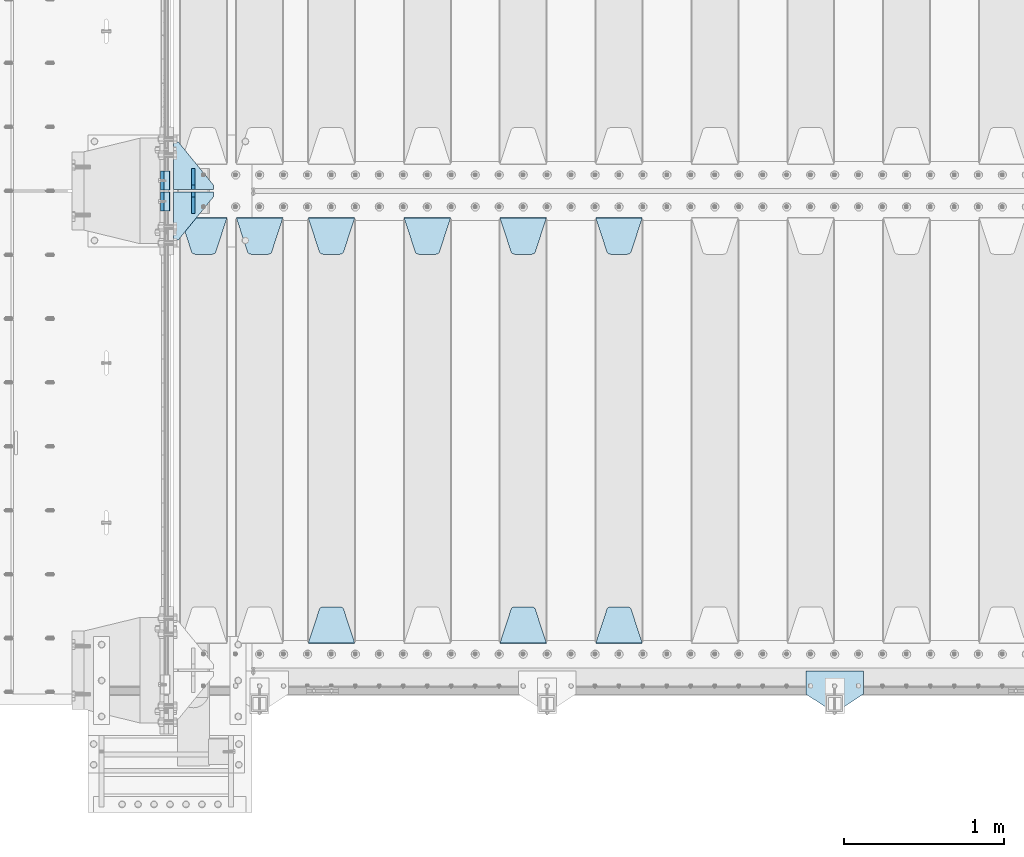
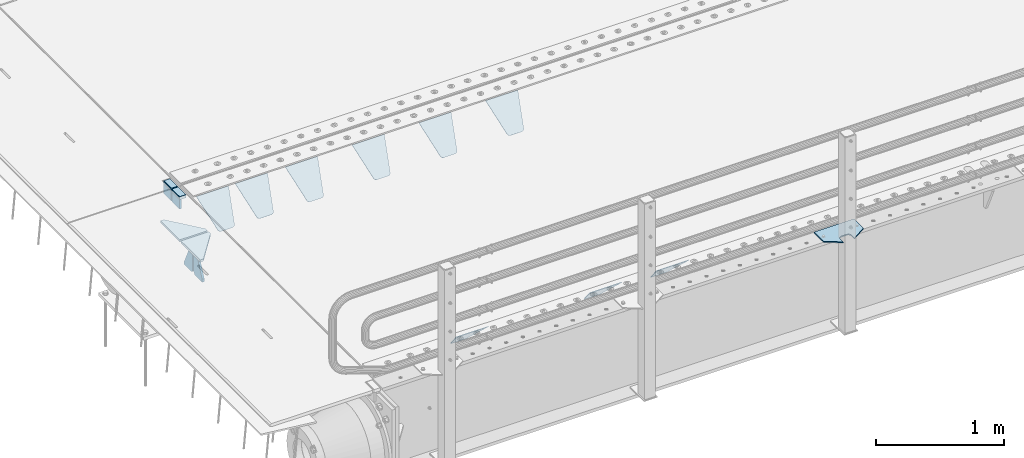
# One storey, part 203 of 257: 18 plates.
"""IFC2X3 building model written with IfcOpenShell, lengths in millimetres."""

import ifcopenshell
import ifcopenshell.guid

model = None  # the IFC model being written
_history = None  # IfcOwnerHistory: only IFC2X3 demands one
_inside = {}  # id of a spatial element -> (the spatial element, [elements in it])
_under = {}  # id of a project, library or spatial element -> (it, [spatial elements below it])
_declared = {}  # id of a project -> (the project, [libraries it declares])
_typed = {}  # id of a type object -> (the type object, [elements of that type])
_made_of = {}  # id of a material, layer set ... -> (it, [elements and type objects made of it])


def new_model(schema):
    """Start an empty IFC model of exactly this schema.

    Asked for "IFC4X3", IfcOpenShell would pick the latest addendum, in which some entities
    have other attributes; the version numbers below select the first issue.
    IFC2X3 requires an IfcOwnerHistory on every rooted entity: one is made here for all.
    """
    global model, _history
    if schema == "IFC4X3":
        model = ifcopenshell.file(schema_version=(4, 3, 0, 0))
    else:
        model = ifcopenshell.file(schema=schema)
    _inside.clear()
    _under.clear()
    _declared.clear()
    _typed.clear()
    _made_of.clear()
    _history = None
    if model.schema == "IFC2X3":
        org = make("IfcOrganization", Name="unknown")
        user = make(
            "IfcPersonAndOrganization",
            ThePerson=make("IfcPerson", FamilyName="unknown"),
            TheOrganization=org,
        )
        app = make(
            "IfcApplication",
            ApplicationDeveloper=org,
            Version="unknown",
            ApplicationFullName="unknown",
            ApplicationIdentifier="unknown",
        )
        _history = make(
            "IfcOwnerHistory",
            OwningUser=user,
            OwningApplication=app,
            ChangeAction="ADDED",
            CreationDate=0,
        )
    return model


def make(cls, **values):
    """One entity of the class cls with the attributes given. An attribute that is None is left unset."""
    return model.create_entity(
        cls, **{name: value for name, value in values.items() if value is not None}
    )


def rooted(cls, **values):
    """An entity with a GlobalId (a new one), such as an element, a storey or a relation."""
    return make(cls, GlobalId=ifcopenshell.guid.new(), OwnerHistory=_history, **values)


def si_unit(unit_type, name, prefix=None):
    """IfcSIUnit, for example si_unit("LENGTHUNIT", "METRE", prefix="MILLI")."""
    return make("IfcSIUnit", UnitType=unit_type, Prefix=prefix, Name=name)


def assignment(units):
    """IfcUnitAssignment: the units of a project."""
    return None if units is None else make("IfcUnitAssignment", Units=units)


def point(xyz):
    """IfcCartesianPoint."""
    return None if xyz is None else make("IfcCartesianPoint", Coordinates=xyz)


def direction(xyz):
    """IfcDirection."""
    return None if xyz is None else make("IfcDirection", DirectionRatios=xyz)


def frame(location, z_axis=None, x_axis=None):
    """IfcAxis2Placement3D, a coordinate frame: its origin and axes. An axis left out is left unset."""
    return make(
        "IfcAxis2Placement3D",
        Location=point(location),
        Axis=direction(z_axis),
        RefDirection=direction(x_axis),
    )


def origin_with_axes():
    """The frame at (0, 0, 0) with the z axis (0, 0, 1) and the x axis (1, 0, 0) written out."""
    return frame((0.0, 0.0, 0.0), z_axis=(0.0, 0.0, 1.0), x_axis=(1.0, 0.0, 0.0))


def place(relative_to, where):
    """IfcLocalPlacement: puts the frame where relative to a parent placement (None: the world)."""
    return make(
        "IfcLocalPlacement", PlacementRelTo=relative_to, RelativePlacement=where
    )


def context(
    kind, dimensions, precision=None, world=None, true_north=None, identifier=None
):
    """IfcGeometricRepresentationContext, for example the 3D "Model" context."""
    return make(
        "IfcGeometricRepresentationContext",
        ContextIdentifier=identifier,
        ContextType=kind,
        CoordinateSpaceDimension=dimensions,
        Precision=precision,
        WorldCoordinateSystem=world,
        TrueNorth=true_north,
    )


def subcontext(parent, identifier, kind, view, scale=None):
    """IfcGeometricRepresentationSubContext, for example "Body" below "Model"."""
    return make(
        "IfcGeometricRepresentationSubContext",
        ContextIdentifier=identifier,
        ContextType=kind,
        ParentContext=parent,
        TargetScale=scale,
        TargetView=view,
    )


def project(units=None, contexts=None):
    """IfcProject with its units and contexts."""
    return rooted(
        "IfcProject",
        Name="project",
        RepresentationContexts=contexts,
        UnitsInContext=assignment(units),
    )


def spatial(cls, under=None, at=None, **own):
    """A site, building, storey or space (cls), placed at a placement, below another one or the project."""
    s = rooted(cls, ObjectPlacement=at, **own)
    if under is not None:
        _under.setdefault(under.id(), (under, []))[1].append(s)
    return s


def faces_of(points, faces, orient=None, outer=None):
    """IfcFace entities. A face is a list of loops; a loop is a list of indices into points, from 0.

    orient and outer hold one flag for each loop. By default every Orientation is true, the
    first loop of a face is its IfcFaceOuterBound and the others are IfcFaceBound.
    """
    made = []
    for i, loops in enumerate(faces):
        bounds = []
        for j, loop in enumerate(loops):
            is_outer = j == 0 if outer is None else outer[i][j]
            bounds.append(
                make(
                    "IfcFaceOuterBound" if is_outer else "IfcFaceBound",
                    Bound=make("IfcPolyLoop", Polygon=[points[k] for k in loop]),
                    Orientation=True if orient is None else orient[i][j],
                )
            )
        made.append(make("IfcFace", Bounds=bounds))
    return made


def faceted_brep(points, faces, orient=None, outer=None, voids=None):
    """IfcFacetedBrep: a solid bounded by flat faces; with voids (closed shells), ...WithVoids."""
    shared = [point(p) for p in points]
    hull = make("IfcClosedShell", CfsFaces=faces_of(shared, faces, orient, outer))
    if voids is None:
        return make("IfcFacetedBrep", Outer=hull)
    return make(
        "IfcFacetedBrepWithVoids",
        Outer=hull,
        Voids=[
            make(cls, CfsFaces=faces_of(shared, fs, o, b)) for cls, fs, o, b in voids
        ],
    )


def shape(context_of_items, identifier, shape_type, items):
    """IfcShapeRepresentation: the items that make up one representation, for example the "Body"."""
    return make(
        "IfcShapeRepresentation",
        ContextOfItems=context_of_items,
        RepresentationIdentifier=identifier,
        RepresentationType=shape_type,
        Items=items,
    )


def material(Name=None, Category=None):
    """IfcMaterial."""
    return make("IfcMaterial", Name=Name, Category=Category)


def made_of(thing, what):
    """Note that an element or type object is made of a material, layer set ...; save() writes the relation."""
    if what is not None:
        _made_of.setdefault(what.id(), (what, []))[1].append(thing)
    return thing


def type_object(cls, material=None, **own):
    """A type object (cls), such as IfcWallType, which elements share."""
    return made_of(rooted(cls, **own), material)


def element(
    cls,
    number,
    at=None,
    inside=None,
    cuts=None,
    type_object=None,
    material=None,
    context=None,
    identifier="Body",
    shape_type=None,
    held_by="IfcProductDefinitionShape",
    body=None,
    shapes=None,
    **own,
):
    """One element of the class cls, such as IfcWall. Its Tag is "e" and its number.

    at: its placement. inside: the storey or other place that contains it. cuts: it is an
    opening in that element (IfcRelVoidsElement). A single representation is given by context,
    identifier, shape_type and body (its items); several are given by shapes. held_by: the class
    of the entity that holds the representations. save() writes the other relations.
    """
    e = rooted(cls, Tag="e%d" % number, ObjectPlacement=at, **own)
    if body is not None:
        shapes = [shape(context, identifier, shape_type, body)]
    if shapes is not None:
        e.Representation = make(held_by, Representations=shapes)
    if inside is not None:
        _inside.setdefault(inside.id(), (inside, []))[1].append(e)
    if cuts is not None:
        rooted(
            "IfcRelVoidsElement", RelatingBuildingElement=cuts, RelatedOpeningElement=e
        )
    if type_object is not None:
        _typed.setdefault(type_object.id(), (type_object, []))[1].append(e)
    return made_of(e, material)


def aggregate(whole, parts):
    """IfcRelAggregates: a whole, such as a stair, and the parts it consists of."""
    return rooted("IfcRelAggregates", RelatingObject=whole, RelatedObjects=parts)


def save(model, path):
    """Write the relations noted so far, then the file.

    IfcRelAggregates (storeys below a building ...), IfcRelContainedInSpatialStructure (elements
    in a storey), IfcRelDefinesByType, IfcRelAssociatesMaterial and IfcRelDeclares: one each for
    every whole, place, type object, material and project.
    """
    for whole, parts in _under.values():
        aggregate(whole, parts)
    for where, things in _inside.values():
        rooted(
            "IfcRelContainedInSpatialStructure",
            RelatedElements=things,
            RelatingStructure=where,
        )
    for kind, things in _typed.values():
        rooted("IfcRelDefinesByType", RelatedObjects=things, RelatingType=kind)
    for what, things in _made_of.values():
        rooted("IfcRelAssociatesMaterial", RelatedObjects=things, RelatingMaterial=what)
    for by, libraries in _declared.values():
        rooted("IfcRelDeclares", RelatingContext=by, RelatedDefinitions=libraries)
    model.write(path)


model = new_model("IFC2X3")

# Units and contexts
model_context = context("Model", 3, precision=1e-05, world=origin_with_axes())
body_context = subcontext(model_context, "Body", "Model", "MODEL_VIEW")
ifc_project = project(units=[si_unit("LENGTHUNIT", "METRE", prefix="MILLI"), si_unit("AREAUNIT", "SQUARE_METRE"), si_unit("VOLUMEUNIT", "CUBIC_METRE"), si_unit("MASSUNIT", "GRAM", prefix="KILO"), si_unit("TIMEUNIT", "SECOND"), si_unit("PLANEANGLEUNIT", "RADIAN"), si_unit("SOLIDANGLEUNIT", "STERADIAN"), si_unit("THERMODYNAMICTEMPERATUREUNIT", "DEGREE_CELSIUS"), si_unit("LUMINOUSINTENSITYUNIT", "LUMEN")], contexts=[model_context])

# Site, building, storey
site_placement = place(None, origin_with_axes())
site = spatial("IfcSite", under=ifc_project, at=site_placement, CompositionType="ELEMENT")
building_placement = place(site_placement, origin_with_axes())
building = spatial("IfcBuilding", under=site, at=building_placement, Name="Standard", CompositionType="ELEMENT")
storey_placement = place(building_placement, origin_with_axes())
storey = spatial("IfcBuildingStorey", under=building, at=storey_placement, Name="Undefined", CompositionType="ELEMENT", Elevation=0.0)

# Plates
ifc_material_1 = material()
plate_type_1 = type_object("IfcPlateType", PredefinedType="NOTDEFINED")
plate_1_placement = place(storey_placement, frame((42440.0, 2935.0, -16.0001127575504), z_axis=(-1.0, 0.0, 0.0), x_axis=(0.0, 0.0, 1.0)))
element("IfcPlate", 1, at=plate_1_placement, inside=storey, type_object=plate_type_1, material=ifc_material_1, context=body_context, shape_type="Brep", body=[
    faceted_brep([(0.0, -60.0, 0.0), (2.49929499318569e-09, -59.9999999999991, 60.0), (2.49929144047201e-09, 60.0000000000005, 60.0), (0.0, 60.0, -7.27595761418343e-12), (25.0146748218828, -59.9999999999991, 60.0), (25.0146748218828, 60.0000000000005, 60.0), (26.5597449794466, -59.9999999999991, 59.7552873949098), (26.5597449794466, 60.0000000000005, 59.7552873949098), (27.9535758796897, -59.9999999999991, 59.0451032832789), (27.9535758796897, 60.0000000000009, 59.0451032832789), (29.0597323263517, -59.9999999999991, 57.9389640667287), (29.0597323263517, 60.0000000000005, 57.9389640667287), (29.7699381491534, -59.9999999999991, 56.5451442289705), (29.7699381491534, 60.0000000000009, 56.5451442289705), (30.0146748212763, -59.9999999999991, 55.0000778834001), (30.0146748212762, 60.0000000000009, 55.0000778834001), (30.0154536553013, -59.9999999999991, 5.00007788340736), (30.0154536553013, 60.0000000000005, 5.00007788340736), (29.7707554908505, -59.9999999999991, 3.45497428546514), (29.7707554908505, 60.0000000000009, 3.45497428546514), (29.0605660948355, -59.9999999999995, 2.06111154406972), (29.0605660948355, 60.0000000000009, 2.06111154406972), (27.9544051209123, -59.9999999999995, 0.954933339693525), (27.9544051209123, 60.0000000000009, 0.954933339693525), (26.5605534420796, -59.9999999999991, 0.244722232011554), (26.5605534420796, 60.0000000000009, 0.244722232011554), (25.0154536559091, -59.9999999999991, 7.27595761418343e-12), (25.0154536559091, 60.0000000000009, 7.27595761418343e-12)], [[[0, 1, 2, 3]], [[1, 4, 5, 2]], [[4, 6, 7, 5]], [[6, 8, 9, 7]], [[8, 10, 11, 9]], [[10, 12, 13, 11]], [[12, 14, 15, 13]], [[14, 16, 17, 15]], [[16, 18, 19, 17]], [[18, 20, 21, 19]], [[20, 22, 23, 21]], [[22, 24, 25, 23]], [[24, 26, 27, 25]], [[26, 0, 3, 27]], [[5, 7, 9, 11, 13, 15, 17, 19, 21, 23, 25, 27, 3, 2]], [[26, 24, 22, 20, 18, 16, 14, 12, 10, 8, 6, 4, 1, 0]]]),
])
plate_2_placement = place(storey_placement, frame((42439.99999994, 3065.00000045221, -16.0146144414428), z_axis=(-1.0, 0.0, 0.0), x_axis=(0.0, -4.95099999998473e-06, 0.999999999987744)))
element("IfcPlate", 2, at=plate_2_placement, inside=storey, type_object=plate_type_1, material=ifc_material_1, context=body_context, shape_type="Brep", body=[
    faceted_brep([(0.0, -60.0, 0.0), (-0.000933120085687023, -60.0, 60.0), (-0.000933120085687023, 60.0, 59.9999999999927), (0.0, 60.0, -7.27595761418343e-12), (24.9991450303709, -60.0, 60.0), (24.9991450303709, 60.0, 59.9999999999927), (26.544215218168, -60.0, 59.7552873850873), (26.544215218168, 60.0, 59.75528738508), (27.9380461396139, -60.0, 59.0451032459096), (27.9380461396139, 60.0, 59.0451032459096), (29.0442025908961, -60.0, 57.9389639895744), (29.0442025908961, 60.0, 57.9389639895744), (29.7544083969366, -60.0, 56.5451441080368), (29.7544083969366, 60.0, 56.5451441080295), (29.9991450297669, -60.0, 55.0000777244568), (29.9991450297669, 60.0, 55.0000777244495), (29.999922274335, -60.0, 5.00007772445679), (29.999922274335, 60.0, 5.00007772444951), (29.7552240705896, -60.0, 3.45497416452417), (29.7552240705896, 60.0, 3.45497416452417), (29.0450346578116, -60.0, 2.06111146690819), (29.0450346578116, 60.0, 2.06111146690819), (27.9388736885072, -60.0, 0.954933302316931), (27.9388736885072, 60.0, 0.954933302316931), (26.5450220308766, -60.0, 0.244722222181736), (26.5450220308766, 60.0, 0.244722222181736), (24.9999222749392, -60.0, 0.0), (24.9999222749392, 60.0, -7.27595761418343e-12)], [[[0, 1, 2, 3]], [[1, 4, 5, 2]], [[4, 6, 7, 5]], [[6, 8, 9, 7]], [[8, 10, 11, 9]], [[10, 12, 13, 11]], [[12, 14, 15, 13]], [[14, 16, 17, 15]], [[16, 18, 19, 17]], [[18, 20, 21, 19]], [[20, 22, 23, 21]], [[22, 24, 25, 23]], [[24, 26, 27, 25]], [[26, 0, 3, 27]], [[5, 7, 9, 11, 13, 15, 17, 19, 21, 23, 25, 27, 3, 2]], [[26, 24, 22, 20, 18, 16, 14, 12, 10, 8, 6, 4, 1, 0]]]),
])
ifc_material_2 = material(Name="STEEL/S355N")
plate_type_2 = type_object("IfcPlateType", PredefinedType="NOTDEFINED")
plate_3_placement = place(storey_placement, frame((42390.0, 2995.00008553452, -105.984447297702), z_axis=(0.0, -1.0, 0.0), x_axis=(0.0, 0.0, 1.0)))
element("IfcPlate", 3, at=plate_3_placement, inside=storey, type_object=plate_type_2, material=ifc_material_2, context=body_context, shape_type="Brep", body=[
    faceted_brep([(0.0, -10.0, 0.0), (5.7072624315424e-07, -10.0, 120.0), (5.7072624315424e-07, 10.0, 120.0), (0.0, 10.0, 0.0), (89.9845046997072, -10.0, 119.999999999999), (89.9845046997072, 10.0, 119.999999999999), (89.9843902587891, -10.0, 6.45741238258779e-11), (89.9843902587891, 10.0, 6.45741238258779e-11)], [[[0, 1, 2, 3]], [[1, 4, 5, 2]], [[4, 6, 7, 5]], [[6, 0, 3, 7]], [[5, 7, 3, 2]], [[6, 4, 1, 0]]]),
])
plate_4_placement = place(storey_placement, frame((42390.0, 3125.00044600192, -106.014939471591), z_axis=(0.0, -0.999999999987744, -4.95099999993769e-06), x_axis=(0.0, -4.95099999998473e-06, 0.999999999987744)))
element("IfcPlate", 4, at=plate_4_placement, inside=storey, type_object=plate_type_2, material=ifc_material_2, context=body_context, shape_type="Brep", body=[
    faceted_brep([(0.0, -10.0, 0.0), (5.7072624315424e-07, -10.0, 120.0), (5.7072624315424e-07, 10.0, 120.0), (0.0, 10.0, 0.0), (90.0, -10.0, 120.0), (90.0, 10.0, 120.0), (90.0, -10.0, 1.09139364212751e-11), (90.0, 10.0, 1.09139364212751e-11)], [[[0, 1, 2, 3]], [[1, 4, 5, 2]], [[4, 6, 7, 5]], [[6, 0, 3, 7]], [[5, 7, 3, 2]], [[6, 4, 1, 0]]]),
])
plate_type_3 = type_object("IfcPlateType", PredefinedType="NOTDEFINED")
plate_5_placement = place(storey_placement, frame((45105.0, 2831.76776695594, -1.767766952965), z_axis=(0.0, -0.707106781186548, -0.707106781186547), x_axis=(1.0, 0.0, 0.0)))
element("IfcPlate", 5, at=plate_5_placement, inside=storey, type_object=plate_type_3, material=ifc_material_2, context=body_context, shape_type="Brep", body=[
    faceted_brep([(0.0, -2.5, 0.0), (69.345504679477, -2.50000000000091, 300.17173142483), (69.345504679477, 2.5, 300.171731424831), (0.0, 2.5, 0.0), (70.927406119954, -2.50000000000091, 304.8974424154), (70.927406119954, 2.5, 304.8974424154), (73.3818627772271, -2.50000000000091, 309.234538108527), (73.3818627772271, 2.49999999999909, 309.234538108527), (76.6187032999587, -2.5, 313.023683126103), (76.6187032999587, 2.5, 313.023683126103), (80.5190132705029, -2.5, 316.125672595372), (80.5190132705029, 2.5, 316.125672595371), (84.9395038596849, -2.5, 318.426546230476), (84.9395038596849, 2.5, 318.426546230477), (89.7177759439219, -2.5, 319.841774983275), (89.7177759439219, 2.5, 319.841774983275), (94.6782862926484, -2.5, 320.319366455079), (94.6782862926484, 2.5, 320.319366455079), (195.321713707352, -2.5, 320.319366455079), (195.321713707352, 2.5, 320.319366455079), (200.282224056078, -2.5, 319.841774983275), (200.282224056078, 2.49999999999909, 319.841774983275), (205.060496140315, -2.5, 318.426546230476), (205.060496140315, 2.49999999999909, 318.426546230475), (209.480986729497, -2.5, 316.125672595371), (209.480986729497, 2.5, 316.125672595371), (213.381296700041, -2.50000000000091, 313.023683126102), (213.381296700041, 2.5, 313.023683126103), (216.618137222766, -2.50000000000091, 309.234538108527), (216.618137222766, 2.5, 309.234538108527), (219.072593880039, -2.5, 304.897442415399), (219.072593880039, 2.5, 304.897442415399), (220.654495320523, -2.50000000000091, 300.17173142483), (220.654495320523, 2.5, 300.171731424831), (290.0, -2.50000000000091, 0.0), (290.0, 2.5, 9.09494701772928e-13)], [[[0, 1, 2, 3]], [[1, 4, 5, 2]], [[4, 6, 7, 5]], [[6, 8, 9, 7]], [[8, 10, 11, 9]], [[10, 12, 13, 11]], [[12, 14, 15, 13]], [[14, 16, 17, 15]], [[16, 18, 19, 17]], [[18, 20, 21, 19]], [[20, 22, 23, 21]], [[22, 24, 25, 23]], [[24, 26, 27, 25]], [[26, 28, 29, 27]], [[28, 30, 31, 29]], [[30, 32, 33, 31]], [[32, 34, 35, 33]], [[34, 0, 3, 35]], [[5, 7, 9, 11, 13, 15, 17, 19, 21, 23, 25, 27, 29, 31, 33, 35, 3, 2]], [[34, 32, 30, 28, 26, 24, 22, 20, 18, 16, 14, 12, 10, 8, 6, 4, 1, 0]]]),
])
plate_6_placement = place(storey_placement, frame((45395.0, 168.232233047034, -1.76776695296758), z_axis=(0.0, 0.707106781186547, -0.707106781186548), x_axis=(-1.0, 0.0, 0.0)))
element("IfcPlate", 6, at=plate_6_placement, inside=storey, type_object=plate_type_3, material=ifc_material_2, context=body_context, shape_type="Brep", body=[
    faceted_brep([(0.0, -2.5, 0.0), (69.345504679477, -2.50000000000091, 300.17173142483), (69.345504679477, 2.5, 300.171731424831), (0.0, 2.5, 0.0), (70.927406119954, -2.50000000000091, 304.8974424154), (70.927406119954, 2.5, 304.8974424154), (73.3818627772271, -2.50000000000091, 309.234538108527), (73.3818627772271, 2.49999999999909, 309.234538108527), (76.6187032999587, -2.5, 313.023683126103), (76.6187032999587, 2.5, 313.023683126103), (80.5190132705029, -2.5, 316.125672595372), (80.5190132705029, 2.5, 316.125672595371), (84.9395038596849, -2.5, 318.426546230476), (84.9395038596849, 2.5, 318.426546230477), (89.7177759439219, -2.5, 319.841774983275), (89.7177759439219, 2.5, 319.841774983275), (94.6782862926484, -2.5, 320.319366455079), (94.6782862926484, 2.5, 320.319366455079), (195.321713707352, -2.5, 320.319366455079), (195.321713707352, 2.5, 320.319366455079), (200.282224056078, -2.5, 319.841774983275), (200.282224056078, 2.49999999999909, 319.841774983275), (205.060496140315, -2.5, 318.426546230476), (205.060496140315, 2.49999999999909, 318.426546230475), (209.480986729497, -2.5, 316.125672595371), (209.480986729497, 2.5, 316.125672595371), (213.381296700041, -2.50000000000091, 313.023683126102), (213.381296700041, 2.5, 313.023683126103), (216.618137222766, -2.50000000000091, 309.234538108527), (216.618137222766, 2.5, 309.234538108527), (219.072593880039, -2.5, 304.897442415399), (219.072593880039, 2.5, 304.897442415399), (220.654495320523, -2.50000000000091, 300.17173142483), (220.654495320523, 2.5, 300.171731424831), (290.0, -2.50000000000091, 0.0), (290.0, 2.5, 9.09494701772928e-13)], [[[0, 1, 2, 3]], [[1, 4, 5, 2]], [[4, 6, 7, 5]], [[6, 8, 9, 7]], [[8, 10, 11, 9]], [[10, 12, 13, 11]], [[12, 14, 15, 13]], [[14, 16, 17, 15]], [[16, 18, 19, 17]], [[18, 20, 21, 19]], [[20, 22, 23, 21]], [[22, 24, 25, 23]], [[24, 26, 27, 25]], [[26, 28, 29, 27]], [[28, 30, 31, 29]], [[30, 32, 33, 31]], [[32, 34, 35, 33]], [[34, 0, 3, 35]], [[5, 7, 9, 11, 13, 15, 17, 19, 21, 23, 25, 27, 29, 31, 33, 35, 3, 2]], [[34, 32, 30, 28, 26, 24, 22, 20, 18, 16, 14, 12, 10, 8, 6, 4, 1, 0]]]),
])
plate_7_placement = place(storey_placement, frame((44505.0, 2831.76776695594, -1.767766952965), z_axis=(0.0, -0.707106781186548, -0.707106781186547), x_axis=(1.0, 0.0, 0.0)))
element("IfcPlate", 7, at=plate_7_placement, inside=storey, type_object=plate_type_3, material=ifc_material_2, context=body_context, shape_type="Brep", body=[
    faceted_brep([(0.0, -2.5, 0.0), (69.345504679477, -2.50000000000091, 300.17173142483), (69.345504679477, 2.5, 300.171731424831), (0.0, 2.5, 0.0), (70.927406119954, -2.50000000000091, 304.8974424154), (70.927406119954, 2.5, 304.8974424154), (73.3818627772271, -2.50000000000091, 309.234538108527), (73.3818627772271, 2.49999999999909, 309.234538108527), (76.6187032999587, -2.5, 313.023683126103), (76.6187032999587, 2.5, 313.023683126103), (80.5190132705029, -2.5, 316.125672595372), (80.5190132705029, 2.5, 316.125672595371), (84.9395038596849, -2.5, 318.426546230476), (84.9395038596849, 2.5, 318.426546230477), (89.7177759439219, -2.5, 319.841774983275), (89.7177759439219, 2.5, 319.841774983275), (94.6782862926484, -2.5, 320.319366455079), (94.6782862926484, 2.5, 320.319366455079), (195.321713707352, -2.5, 320.319366455079), (195.321713707352, 2.5, 320.319366455079), (200.282224056078, -2.5, 319.841774983275), (200.282224056078, 2.49999999999909, 319.841774983275), (205.060496140315, -2.5, 318.426546230476), (205.060496140315, 2.49999999999909, 318.426546230475), (209.480986729497, -2.5, 316.125672595371), (209.480986729497, 2.5, 316.125672595371), (213.381296700041, -2.50000000000091, 313.023683126102), (213.381296700041, 2.5, 313.023683126103), (216.618137222766, -2.50000000000091, 309.234538108527), (216.618137222766, 2.5, 309.234538108527), (219.072593880039, -2.5, 304.897442415399), (219.072593880039, 2.5, 304.897442415399), (220.654495320523, -2.50000000000091, 300.17173142483), (220.654495320523, 2.5, 300.171731424831), (290.0, -2.50000000000091, 0.0), (290.0, 2.5, 9.09494701772928e-13)], [[[0, 1, 2, 3]], [[1, 4, 5, 2]], [[4, 6, 7, 5]], [[6, 8, 9, 7]], [[8, 10, 11, 9]], [[10, 12, 13, 11]], [[12, 14, 15, 13]], [[14, 16, 17, 15]], [[16, 18, 19, 17]], [[18, 20, 21, 19]], [[20, 22, 23, 21]], [[22, 24, 25, 23]], [[24, 26, 27, 25]], [[26, 28, 29, 27]], [[28, 30, 31, 29]], [[30, 32, 33, 31]], [[32, 34, 35, 33]], [[34, 0, 3, 35]], [[5, 7, 9, 11, 13, 15, 17, 19, 21, 23, 25, 27, 29, 31, 33, 35, 3, 2]], [[34, 32, 30, 28, 26, 24, 22, 20, 18, 16, 14, 12, 10, 8, 6, 4, 1, 0]]]),
])
plate_8_placement = place(storey_placement, frame((44795.0, 168.232233047034, -1.76776695296758), z_axis=(0.0, 0.707106781186547, -0.707106781186548), x_axis=(-1.0, 0.0, 0.0)))
element("IfcPlate", 8, at=plate_8_placement, inside=storey, type_object=plate_type_3, material=ifc_material_2, context=body_context, shape_type="Brep", body=[
    faceted_brep([(0.0, -2.5, 0.0), (69.345504679477, -2.50000000000091, 300.17173142483), (69.345504679477, 2.5, 300.171731424831), (0.0, 2.5, 0.0), (70.927406119954, -2.50000000000091, 304.8974424154), (70.927406119954, 2.5, 304.8974424154), (73.3818627772271, -2.50000000000091, 309.234538108527), (73.3818627772271, 2.49999999999909, 309.234538108527), (76.6187032999587, -2.5, 313.023683126103), (76.6187032999587, 2.5, 313.023683126103), (80.5190132705029, -2.5, 316.125672595372), (80.5190132705029, 2.5, 316.125672595371), (84.9395038596849, -2.5, 318.426546230476), (84.9395038596849, 2.5, 318.426546230477), (89.7177759439219, -2.5, 319.841774983275), (89.7177759439219, 2.5, 319.841774983275), (94.6782862926484, -2.5, 320.319366455079), (94.6782862926484, 2.5, 320.319366455079), (195.321713707352, -2.5, 320.319366455079), (195.321713707352, 2.5, 320.319366455079), (200.282224056078, -2.5, 319.841774983275), (200.282224056078, 2.49999999999909, 319.841774983275), (205.060496140315, -2.5, 318.426546230476), (205.060496140315, 2.49999999999909, 318.426546230475), (209.480986729497, -2.5, 316.125672595371), (209.480986729497, 2.5, 316.125672595371), (213.381296700041, -2.50000000000091, 313.023683126102), (213.381296700041, 2.5, 313.023683126103), (216.618137222766, -2.50000000000091, 309.234538108527), (216.618137222766, 2.5, 309.234538108527), (219.072593880039, -2.5, 304.897442415399), (219.072593880039, 2.5, 304.897442415399), (220.654495320523, -2.50000000000091, 300.17173142483), (220.654495320523, 2.5, 300.171731424831), (290.0, -2.50000000000091, 0.0), (290.0, 2.5, 9.09494701772928e-13)], [[[0, 1, 2, 3]], [[1, 4, 5, 2]], [[4, 6, 7, 5]], [[6, 8, 9, 7]], [[8, 10, 11, 9]], [[10, 12, 13, 11]], [[12, 14, 15, 13]], [[14, 16, 17, 15]], [[16, 18, 19, 17]], [[18, 20, 21, 19]], [[20, 22, 23, 21]], [[22, 24, 25, 23]], [[24, 26, 27, 25]], [[26, 28, 29, 27]], [[28, 30, 31, 29]], [[30, 32, 33, 31]], [[32, 34, 35, 33]], [[34, 0, 3, 35]], [[5, 7, 9, 11, 13, 15, 17, 19, 21, 23, 25, 27, 29, 31, 33, 35, 3, 2]], [[34, 32, 30, 28, 26, 24, 22, 20, 18, 16, 14, 12, 10, 8, 6, 4, 1, 0]]]),
])
plate_9_placement = place(storey_placement, frame((43905.0, 2831.76776695594, -1.767766952965), z_axis=(0.0, -0.707106781186548, -0.707106781186547), x_axis=(1.0, 0.0, 0.0)))
element("IfcPlate", 9, at=plate_9_placement, inside=storey, type_object=plate_type_3, material=ifc_material_2, context=body_context, shape_type="Brep", body=[
    faceted_brep([(0.0, -2.5, 0.0), (69.345504679477, -2.50000000000091, 300.17173142483), (69.345504679477, 2.5, 300.171731424831), (0.0, 2.5, 0.0), (70.927406119954, -2.50000000000091, 304.8974424154), (70.927406119954, 2.5, 304.8974424154), (73.3818627772271, -2.50000000000091, 309.234538108527), (73.3818627772271, 2.49999999999909, 309.234538108527), (76.6187032999587, -2.5, 313.023683126103), (76.6187032999587, 2.5, 313.023683126103), (80.5190132705029, -2.5, 316.125672595372), (80.5190132705029, 2.5, 316.125672595371), (84.9395038596849, -2.5, 318.426546230476), (84.9395038596849, 2.5, 318.426546230477), (89.7177759439219, -2.5, 319.841774983275), (89.7177759439219, 2.5, 319.841774983275), (94.6782862926484, -2.5, 320.319366455079), (94.6782862926484, 2.5, 320.319366455079), (195.321713707352, -2.5, 320.319366455079), (195.321713707352, 2.5, 320.319366455079), (200.282224056078, -2.5, 319.841774983275), (200.282224056078, 2.49999999999909, 319.841774983275), (205.060496140315, -2.5, 318.426546230476), (205.060496140315, 2.49999999999909, 318.426546230475), (209.480986729497, -2.5, 316.125672595371), (209.480986729497, 2.5, 316.125672595371), (213.381296700041, -2.50000000000091, 313.023683126102), (213.381296700041, 2.5, 313.023683126103), (216.618137222766, -2.50000000000091, 309.234538108527), (216.618137222766, 2.5, 309.234538108527), (219.072593880039, -2.5, 304.897442415399), (219.072593880039, 2.5, 304.897442415399), (220.654495320523, -2.50000000000091, 300.17173142483), (220.654495320523, 2.5, 300.171731424831), (290.0, -2.50000000000091, 0.0), (290.0, 2.5, 9.09494701772928e-13)], [[[0, 1, 2, 3]], [[1, 4, 5, 2]], [[4, 6, 7, 5]], [[6, 8, 9, 7]], [[8, 10, 11, 9]], [[10, 12, 13, 11]], [[12, 14, 15, 13]], [[14, 16, 17, 15]], [[16, 18, 19, 17]], [[18, 20, 21, 19]], [[20, 22, 23, 21]], [[22, 24, 25, 23]], [[24, 26, 27, 25]], [[26, 28, 29, 27]], [[28, 30, 31, 29]], [[30, 32, 33, 31]], [[32, 34, 35, 33]], [[34, 0, 3, 35]], [[5, 7, 9, 11, 13, 15, 17, 19, 21, 23, 25, 27, 29, 31, 33, 35, 3, 2]], [[34, 32, 30, 28, 26, 24, 22, 20, 18, 16, 14, 12, 10, 8, 6, 4, 1, 0]]]),
])
plate_10_placement = place(storey_placement, frame((43305.0, 2831.76776695594, -1.767766952965), z_axis=(0.0, -0.707106781186548, -0.707106781186547), x_axis=(1.0, 0.0, 0.0)))
element("IfcPlate", 10, at=plate_10_placement, inside=storey, type_object=plate_type_3, material=ifc_material_2, context=body_context, shape_type="Brep", body=[
    faceted_brep([(0.0, -2.5, 0.0), (69.345504679477, -2.50000000000091, 300.17173142483), (69.345504679477, 2.5, 300.171731424831), (0.0, 2.5, 0.0), (70.927406119954, -2.50000000000091, 304.8974424154), (70.927406119954, 2.5, 304.8974424154), (73.3818627772271, -2.50000000000091, 309.234538108527), (73.3818627772271, 2.49999999999909, 309.234538108527), (76.6187032999587, -2.5, 313.023683126103), (76.6187032999587, 2.5, 313.023683126103), (80.5190132705029, -2.5, 316.125672595372), (80.5190132705029, 2.5, 316.125672595371), (84.9395038596849, -2.5, 318.426546230476), (84.9395038596849, 2.5, 318.426546230477), (89.7177759439219, -2.5, 319.841774983275), (89.7177759439219, 2.5, 319.841774983275), (94.6782862926484, -2.5, 320.319366455079), (94.6782862926484, 2.5, 320.319366455079), (195.321713707352, -2.5, 320.319366455079), (195.321713707352, 2.5, 320.319366455079), (200.282224056078, -2.5, 319.841774983275), (200.282224056078, 2.49999999999909, 319.841774983275), (205.060496140315, -2.5, 318.426546230476), (205.060496140315, 2.49999999999909, 318.426546230475), (209.480986729497, -2.5, 316.125672595371), (209.480986729497, 2.5, 316.125672595371), (213.381296700041, -2.50000000000091, 313.023683126102), (213.381296700041, 2.5, 313.023683126103), (216.618137222766, -2.50000000000091, 309.234538108527), (216.618137222766, 2.5, 309.234538108527), (219.072593880039, -2.5, 304.897442415399), (219.072593880039, 2.5, 304.897442415399), (220.654495320523, -2.50000000000091, 300.17173142483), (220.654495320523, 2.5, 300.171731424831), (290.0, -2.50000000000091, 0.0), (290.0, 2.5, 9.09494701772928e-13)], [[[0, 1, 2, 3]], [[1, 4, 5, 2]], [[4, 6, 7, 5]], [[6, 8, 9, 7]], [[8, 10, 11, 9]], [[10, 12, 13, 11]], [[12, 14, 15, 13]], [[14, 16, 17, 15]], [[16, 18, 19, 17]], [[18, 20, 21, 19]], [[20, 22, 23, 21]], [[22, 24, 25, 23]], [[24, 26, 27, 25]], [[26, 28, 29, 27]], [[28, 30, 31, 29]], [[30, 32, 33, 31]], [[32, 34, 35, 33]], [[34, 0, 3, 35]], [[5, 7, 9, 11, 13, 15, 17, 19, 21, 23, 25, 27, 29, 31, 33, 35, 3, 2]], [[34, 32, 30, 28, 26, 24, 22, 20, 18, 16, 14, 12, 10, 8, 6, 4, 1, 0]]]),
])
plate_11_placement = place(storey_placement, frame((43595.0, 168.232233047034, -1.76776695296758), z_axis=(0.0, 0.707106781186547, -0.707106781186548), x_axis=(-1.0, 0.0, 0.0)))
element("IfcPlate", 11, at=plate_11_placement, inside=storey, type_object=plate_type_3, material=ifc_material_2, context=body_context, shape_type="Brep", body=[
    faceted_brep([(0.0, -2.5, 0.0), (69.345504679477, -2.50000000000091, 300.17173142483), (69.345504679477, 2.5, 300.171731424831), (0.0, 2.5, 0.0), (70.927406119954, -2.50000000000091, 304.8974424154), (70.927406119954, 2.5, 304.8974424154), (73.3818627772271, -2.50000000000091, 309.234538108527), (73.3818627772271, 2.49999999999909, 309.234538108527), (76.6187032999587, -2.5, 313.023683126103), (76.6187032999587, 2.5, 313.023683126103), (80.5190132705029, -2.5, 316.125672595372), (80.5190132705029, 2.5, 316.125672595371), (84.9395038596849, -2.5, 318.426546230476), (84.9395038596849, 2.5, 318.426546230477), (89.7177759439219, -2.5, 319.841774983275), (89.7177759439219, 2.5, 319.841774983275), (94.6782862926484, -2.5, 320.319366455079), (94.6782862926484, 2.5, 320.319366455079), (195.321713707352, -2.5, 320.319366455079), (195.321713707352, 2.5, 320.319366455079), (200.282224056078, -2.5, 319.841774983275), (200.282224056078, 2.49999999999909, 319.841774983275), (205.060496140315, -2.5, 318.426546230476), (205.060496140315, 2.49999999999909, 318.426546230475), (209.480986729497, -2.5, 316.125672595371), (209.480986729497, 2.5, 316.125672595371), (213.381296700041, -2.50000000000091, 313.023683126102), (213.381296700041, 2.5, 313.023683126103), (216.618137222766, -2.50000000000091, 309.234538108527), (216.618137222766, 2.5, 309.234538108527), (219.072593880039, -2.5, 304.897442415399), (219.072593880039, 2.5, 304.897442415399), (220.654495320523, -2.50000000000091, 300.17173142483), (220.654495320523, 2.5, 300.171731424831), (290.0, -2.50000000000091, 0.0), (290.0, 2.5, 9.09494701772928e-13)], [[[0, 1, 2, 3]], [[1, 4, 5, 2]], [[4, 6, 7, 5]], [[6, 8, 9, 7]], [[8, 10, 11, 9]], [[10, 12, 13, 11]], [[12, 14, 15, 13]], [[14, 16, 17, 15]], [[16, 18, 19, 17]], [[18, 20, 21, 19]], [[20, 22, 23, 21]], [[22, 24, 25, 23]], [[24, 26, 27, 25]], [[26, 28, 29, 27]], [[28, 30, 31, 29]], [[30, 32, 33, 31]], [[32, 34, 35, 33]], [[34, 0, 3, 35]], [[5, 7, 9, 11, 13, 15, 17, 19, 21, 23, 25, 27, 29, 31, 33, 35, 3, 2]], [[34, 32, 30, 28, 26, 24, 22, 20, 18, 16, 14, 12, 10, 8, 6, 4, 1, 0]]]),
])
plate_12_placement = place(storey_placement, frame((42855.0, 2831.76776695594, -1.767766952965), z_axis=(0.0, -0.707106781186548, -0.707106781186547), x_axis=(1.0, 0.0, 0.0)))
element("IfcPlate", 12, at=plate_12_placement, inside=storey, type_object=plate_type_3, material=ifc_material_2, context=body_context, shape_type="Brep", body=[
    faceted_brep([(0.0, -2.5, 0.0), (69.345504679477, -2.50000000000091, 300.17173142483), (69.345504679477, 2.5, 300.171731424831), (0.0, 2.5, 0.0), (70.927406119954, -2.50000000000091, 304.8974424154), (70.927406119954, 2.5, 304.8974424154), (73.3818627772271, -2.50000000000091, 309.234538108527), (73.3818627772271, 2.49999999999909, 309.234538108527), (76.6187032999587, -2.5, 313.023683126103), (76.6187032999587, 2.5, 313.023683126103), (80.5190132705029, -2.5, 316.125672595372), (80.5190132705029, 2.5, 316.125672595371), (84.9395038596849, -2.5, 318.426546230476), (84.9395038596849, 2.5, 318.426546230477), (89.7177759439219, -2.5, 319.841774983275), (89.7177759439219, 2.5, 319.841774983275), (94.6782862926484, -2.5, 320.319366455079), (94.6782862926484, 2.5, 320.319366455079), (195.321713707352, -2.5, 320.319366455079), (195.321713707352, 2.5, 320.319366455079), (200.282224056078, -2.5, 319.841774983275), (200.282224056078, 2.49999999999909, 319.841774983275), (205.060496140315, -2.5, 318.426546230476), (205.060496140315, 2.49999999999909, 318.426546230475), (209.480986729497, -2.5, 316.125672595371), (209.480986729497, 2.5, 316.125672595371), (213.381296700041, -2.50000000000091, 313.023683126102), (213.381296700041, 2.5, 313.023683126103), (216.618137222766, -2.50000000000091, 309.234538108527), (216.618137222766, 2.5, 309.234538108527), (219.072593880039, -2.5, 304.897442415399), (219.072593880039, 2.5, 304.897442415399), (220.654495320523, -2.50000000000091, 300.17173142483), (220.654495320523, 2.5, 300.171731424831), (290.0, -2.50000000000091, 0.0), (290.0, 2.5, 9.09494701772928e-13)], [[[0, 1, 2, 3]], [[1, 4, 5, 2]], [[4, 6, 7, 5]], [[6, 8, 9, 7]], [[8, 10, 11, 9]], [[10, 12, 13, 11]], [[12, 14, 15, 13]], [[14, 16, 17, 15]], [[16, 18, 19, 17]], [[18, 20, 21, 19]], [[20, 22, 23, 21]], [[22, 24, 25, 23]], [[24, 26, 27, 25]], [[26, 28, 29, 27]], [[28, 30, 31, 29]], [[30, 32, 33, 31]], [[32, 34, 35, 33]], [[34, 0, 3, 35]], [[5, 7, 9, 11, 13, 15, 17, 19, 21, 23, 25, 27, 29, 31, 33, 35, 3, 2]], [[34, 32, 30, 28, 26, 24, 22, 20, 18, 16, 14, 12, 10, 8, 6, 4, 1, 0]]]),
])
plate_13_placement = place(storey_placement, frame((42505.0, 2831.76776695594, -1.767766952965), z_axis=(0.0, -0.707106781186548, -0.707106781186547), x_axis=(1.0, 0.0, 0.0)))
element("IfcPlate", 13, at=plate_13_placement, inside=storey, type_object=plate_type_3, material=ifc_material_2, context=body_context, shape_type="Brep", body=[
    faceted_brep([(0.0, -2.5, 0.0), (69.345504679477, -2.50000000000091, 300.17173142483), (69.345504679477, 2.5, 300.171731424831), (0.0, 2.5, 0.0), (70.927406119954, -2.50000000000091, 304.8974424154), (70.927406119954, 2.5, 304.8974424154), (73.3818627772271, -2.50000000000091, 309.234538108527), (73.3818627772271, 2.49999999999909, 309.234538108527), (76.6187032999587, -2.5, 313.023683126103), (76.6187032999587, 2.5, 313.023683126103), (80.5190132705029, -2.5, 316.125672595372), (80.5190132705029, 2.5, 316.125672595371), (84.9395038596849, -2.5, 318.426546230476), (84.9395038596849, 2.5, 318.426546230477), (89.7177759439219, -2.5, 319.841774983275), (89.7177759439219, 2.5, 319.841774983275), (94.6782862926484, -2.5, 320.319366455079), (94.6782862926484, 2.5, 320.319366455079), (195.321713707352, -2.5, 320.319366455079), (195.321713707352, 2.5, 320.319366455079), (200.282224056078, -2.5, 319.841774983275), (200.282224056078, 2.49999999999909, 319.841774983275), (205.060496140315, -2.5, 318.426546230476), (205.060496140315, 2.49999999999909, 318.426546230475), (209.480986729497, -2.5, 316.125672595371), (209.480986729497, 2.5, 316.125672595371), (213.381296700041, -2.50000000000091, 313.023683126102), (213.381296700041, 2.5, 313.023683126103), (216.618137222766, -2.50000000000091, 309.234538108527), (216.618137222766, 2.5, 309.234538108527), (219.072593880039, -2.5, 304.897442415399), (219.072593880039, 2.5, 304.897442415399), (220.654495320523, -2.50000000000091, 300.17173142483), (220.654495320523, 2.5, 300.171731424831), (290.0, -2.50000000000091, 0.0), (290.0, 2.5, 9.09494701772928e-13)], [[[0, 1, 2, 3]], [[1, 4, 5, 2]], [[4, 6, 7, 5]], [[6, 8, 9, 7]], [[8, 10, 11, 9]], [[10, 12, 13, 11]], [[12, 14, 15, 13]], [[14, 16, 17, 15]], [[16, 18, 19, 17]], [[18, 20, 21, 19]], [[20, 22, 23, 21]], [[22, 24, 25, 23]], [[24, 26, 27, 25]], [[26, 28, 29, 27]], [[28, 30, 31, 29]], [[30, 32, 33, 31]], [[32, 34, 35, 33]], [[34, 0, 3, 35]], [[5, 7, 9, 11, 13, 15, 17, 19, 21, 23, 25, 27, 29, 31, 33, 35, 3, 2]], [[34, 32, 30, 28, 26, 24, 22, 20, 18, 16, 14, 12, 10, 8, 6, 4, 1, 0]]]),
])
plate_type_4 = type_object("IfcPlateType", PredefinedType="NOTDEFINED")
for number, where, z_axis, x_axis in (
    (14, (42710.0, 3008.0, -515.0), (0.0, 1.0, 0.0), (-1.0, 0.0, 0.0)),
    (15, (42710.0, 2992.0, -515.0), (0.0, -1.0, 0.0), (-1.0, 0.0, 0.0)),
):
    element("IfcPlate", number, at=place(storey_placement, frame(where, z_axis=z_axis, x_axis=x_axis)), inside=storey, type_object=plate_type_4, material=ifc_material_2, context=body_context, shape_type="Brep", body=[
        faceted_brep([(0.0, -10.0, 0.0), (0.0, -10.0, 30.0), (0.0, 10.0, 30.0), (0.0, 10.0, 0.0), (220.0, -10.0, 300.0), (220.0, 10.0, 300.0), (250.0, -10.0, 300.0), (250.0, 10.0, 300.0), (250.0, -10.0, 0.0), (250.0, 10.0, 0.0)], [[[0, 1, 2, 3]], [[1, 4, 5, 2]], [[4, 6, 7, 5]], [[6, 8, 9, 7]], [[8, 0, 3, 9]], [[5, 7, 9, 3, 2]], [[8, 6, 4, 1, 0]]]),
    ])
plate_type_5 = type_object("IfcPlateType", PredefinedType="NOTDEFINED")
for number, where, z_axis, x_axis in (
    (16, (42585.0, 3140.0, -860.0), (0.0, 0.0, 1.0), (0.0, -1.0, 0.0)),
    (17, (42585.0, 2860.0, -860.0), (0.0, 0.0, 1.0), (0.0, 1.0, 0.0)),
):
    element("IfcPlate", number, at=place(storey_placement, frame(where, z_axis=z_axis, x_axis=x_axis)), inside=storey, type_object=plate_type_5, material=ifc_material_2, context=body_context, shape_type="Brep", body=[
        faceted_brep([(0.0, -10.0, 0.0), (0.0, -10.0, 30.0), (0.0, 10.0, 30.0), (0.0, 10.0, 0.0), (102.0, -10.0, 250.0), (102.0, 10.0, 250.0), (132.0, -10.0, 250.0), (132.0, 10.0, 250.0), (132.0, -10.0, 30.0), (132.0, 10.0, 30.0), (131.544232590366, -10.0, 24.790554669992), (131.544232590366, 10.0, 24.790554669992), (130.190778623577, -10.0, 19.7393957002299), (130.190778623577, 10.0, 19.7393957002299), (127.980762113533, -10.0, 15.0), (127.980762113533, 10.0, 15.0), (124.981333293569, -10.0, 10.7163717094038), (124.981333293569, 10.0, 10.7163717094038), (121.283628290596, -10.0, 7.01866670643062), (121.283628290596, 10.0, 7.01866670643062), (117.0, -10.0, 4.01923788646684), (117.0, 10.0, 4.01923788646684), (112.26060429977, -10.0, 1.80922137642278), (112.26060429977, 10.0, 1.80922137642278), (107.209445330008, -10.0, 0.455767409633722), (107.209445330008, 10.0, 0.455767409633722), (102.0, -10.0, 0.0), (102.0, 10.0, 0.0)], [[[0, 1, 2, 3]], [[1, 4, 5, 2]], [[4, 6, 7, 5]], [[6, 8, 9, 7]], [[8, 10, 11, 9]], [[10, 12, 13, 11]], [[12, 14, 15, 13]], [[14, 16, 17, 15]], [[16, 18, 19, 17]], [[18, 20, 21, 19]], [[20, 22, 23, 21]], [[22, 24, 25, 23]], [[24, 26, 27, 25]], [[26, 0, 3, 27]], [[5, 7, 9, 11, 13, 15, 17, 19, 21, 23, 25, 27, 3, 2]], [[26, 24, 22, 20, 18, 16, 14, 12, 10, 8, 6, 4, 1, 0]]]),
    ])
ifc_material_3 = material(Name="STEEL/S355J2")
plate_type_6 = type_object("IfcPlateType", PredefinedType="NOTDEFINED")
plate_14_placement = place(storey_placement, frame((46780.0, -4.99999999999636, 5.00000000004911), z_axis=(0.0, -1.0, 0.0), x_axis=(-1.0, 0.0, 0.0)))
element("IfcPlate", 18, at=plate_14_placement, inside=storey, type_object=plate_type_6, material=ifc_material_3, context=body_context, shape_type="Brep", body=[
    faceted_brep([(0.0, -5.0, 0.0), (2.31396552408114e-06, -5.0, 145.0), (2.31396552408114e-06, 5.0, 145.0), (0.0, 5.0, 0.0), (130.0, -5.0, 230.0), (130.0, 5.0, 230.0), (130.0, -5.0, 180.0), (130.0, 5.0, 180.0), (130.48036798992, -5.0, 175.122741949597), (130.48036798992, 5.0, 175.122741949597), (131.903011687216, -5.0, 170.432914190873), (131.903011687216, 5.0, 170.432914190873), (134.213259692435, -5.0, 166.11074417451), (134.213259692435, 5.0, 166.11074417451), (137.322330470335, -5.0, 162.322330470337), (137.322330470335, 5.0, 162.322330470337), (141.110744174512, -5.0, 159.213259692437), (141.110744174512, 5.0, 159.213259692437), (145.432914190875, -5.0, 156.903011687218), (145.432914190875, 5.0, 156.903011687218), (150.122741949599, -5.0, 155.48036798992), (150.122741949599, 5.0, 155.48036798992), (155.0, -5.0, 155.0), (155.0, 5.0, 155.0), (205.0, -5.0, 155.0), (205.0, 5.0, 155.0), (209.877258050401, -5.0, 155.48036798992), (209.877258050401, 5.0, 155.48036798992), (214.567085809125, -5.0, 156.903011687218), (214.567085809125, 5.0, 156.903011687218), (218.889255825488, -5.0, 159.213259692437), (218.889255825488, 5.0, 159.213259692437), (222.677669529665, -5.0, 162.322330470337), (222.677669529665, 5.0, 162.322330470337), (225.786740307565, -5.0, 166.11074417451), (225.786740307565, 5.0, 166.11074417451), (228.096988312784, -5.0, 170.432914190873), (228.096988312784, 5.0, 170.432914190873), (229.51963201008, -5.0, 175.122741949597), (229.51963201008, 5.0, 175.122741949597), (230.0, -5.0, 180.0), (230.0, 5.0, 180.0), (230.0, -5.0, 230.0), (230.0, 5.0, 230.0), (360.0, -5.0, 145.0), (360.0, 5.0, 145.0), (360.0, -5.0, -7.27595761418343e-12), (360.0, 5.0, -7.27595761418343e-12)], [[[0, 1, 2, 3]], [[1, 4, 5, 2]], [[4, 6, 7, 5]], [[6, 8, 9, 7]], [[8, 10, 11, 9]], [[10, 12, 13, 11]], [[12, 14, 15, 13]], [[14, 16, 17, 15]], [[16, 18, 19, 17]], [[18, 20, 21, 19]], [[20, 22, 23, 21]], [[22, 24, 25, 23]], [[24, 26, 27, 25]], [[26, 28, 29, 27]], [[28, 30, 31, 29]], [[30, 32, 33, 31]], [[32, 34, 35, 33]], [[34, 36, 37, 35]], [[36, 38, 39, 37]], [[38, 40, 41, 39]], [[40, 42, 43, 41]], [[42, 44, 45, 43]], [[44, 46, 47, 45]], [[46, 0, 3, 47]], [[5, 7, 9, 11, 13, 15, 17, 19, 21, 23, 25, 27, 29, 31, 33, 35, 37, 39, 41, 43, 45, 47, 3, 2]], [[46, 44, 42, 40, 38, 36, 34, 32, 30, 28, 26, 24, 22, 20, 18, 16, 14, 12, 10, 8, 6, 4, 1, 0]]]),
])

save(model, "model.ifc")
